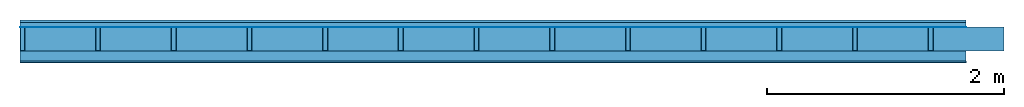
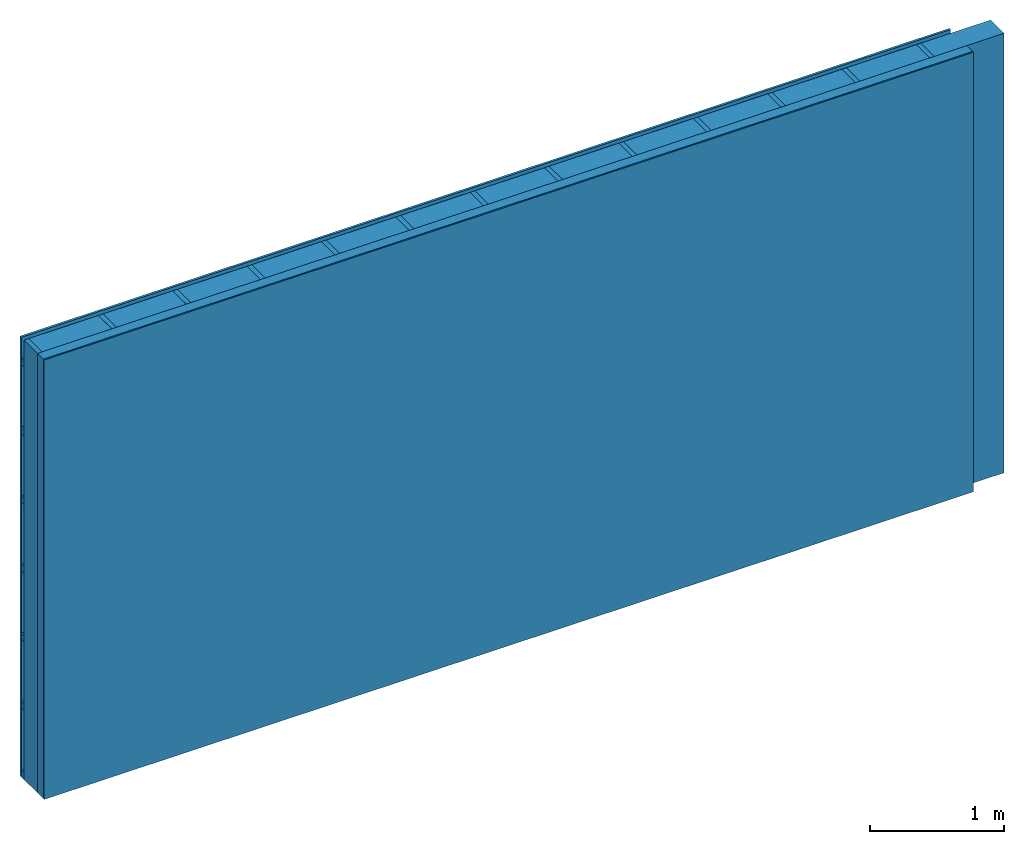
# One storey: 4 plates, 3 members, 1 element without a shape of its own.
"""IFC4 building model written with IfcOpenShell, lengths in metres."""

from ifc_helpers import new_model, si_unit, derived_unit, direction, frame, frame_2d, origin, origin_with_axes, place, context, project, spatial, rectangle, extrude, material, layer, layer_set, type_object, element, aggregate, save


model = new_model("IFC4")

# Units and contexts
plan_context = context("Plan", 3, precision=1e-05, world=origin(), true_north=direction((0.0, 1.0)))
model_context = context("Model", 3, precision=1e-05, world=origin(), true_north=direction((0.0, 1.0)))
ifc_project = project(units=[si_unit("LENGTHUNIT", "METRE"), derived_unit("SOUNDPRESSUREUNIT", [(si_unit("PRESSUREUNIT", "PASCAL", prefix="MICRO"), 0)]), si_unit("ENERGYUNIT", "JOULE", prefix="MEGA"), si_unit("MASSUNIT", "GRAM", prefix="KILO"), derived_unit("THERMALTRANSMITTANCEUNIT", [(si_unit("POWERUNIT", "WATT"), 1), (si_unit("AREAUNIT", "SQUARE_METRE"), -1), (si_unit("THERMODYNAMICTEMPERATUREUNIT", "KELVIN"), -1)]), derived_unit("AREADENSITYUNIT", [(si_unit("MASSUNIT", "GRAM", prefix="KILO"), 1), (si_unit("AREAUNIT", "SQUARE_METRE"), -1)]), derived_unit("USERDEFINED", [(si_unit("ENERGYUNIT", "JOULE", prefix="MEGA"), 1), (si_unit("AREAUNIT", "SQUARE_METRE"), -1)])], contexts=[plan_context, model_context])

# Site, building, storey
site = spatial("IfcSite", under=ifc_project)
building_placement = place(None, origin())
building = spatial("IfcBuilding", under=site, at=building_placement)
storey_placement = place(building_placement, origin())
storey = spatial("IfcBuildingStorey", under=building, at=storey_placement)

# Wall, members, plates
ifc_material_1 = material(Name="Wood cladding horizontal, closed")
ifc_layer_1 = layer(ifc_material_1, 0.02, Name="Cover 1st layer")
ifc_layer_2 = layer(None, 0.04, Name="Battens / profiles (ventilation)")
ifc_material_2 = material(Name="Vapor-permeable water barrier", Category="09.006")
ifc_layer_3 = layer(ifc_material_2, 0.0005, Name="outside 1st layer")
ifc_material_3 = material(Name="of the art")
ifc_layer_4 = layer(ifc_material_3, 0.0, Name="Bond")
ifc_layer_5 = layer(None, 0.2, Name="Support")
ifc_layer_6 = layer(ifc_material_3, 0.0, Name="Bond")
ifc_material_4 = material(Name="Solid timber panel")
ifc_layer_7 = layer(ifc_material_4, 0.087, Name="1st layer")
ifc_material_5 = material(Name="Plasterboard type A", Category="03.008")
ifc_layer_8 = layer(ifc_material_5, 0.0125, Name="Covering 1st layer")
ifc_material_6 = material(Name="joints", Category="04.017")
ifc_layer_9 = layer(ifc_material_6, 0.0, Name="Surface")
ifc_layer_set = layer_set([ifc_layer_1, ifc_layer_2, ifc_layer_3, ifc_layer_4, ifc_layer_5, ifc_layer_6, ifc_layer_7, ifc_layer_8, ifc_layer_9])
wall_type = type_object("IfcWallType", Name="D0985", PredefinedType="NOTDEFINED", material=ifc_layer_set)
wall_placement = place(None, frame((0.0, 0.0, 0.0), z_axis=(0.0, -1.0, 0.0), x_axis=(1.0, 0.0, 0.0)))
wall = element("IfcWall", 1, at=wall_placement, inside=storey, type_object=wall_type, material=ifc_layer_set, Name="Wall #1")
ifc_material_7 = material()
member_1_placement = place(wall_placement, origin())
member_1 = element("IfcMember", 2, at=member_1_placement, material=ifc_material_7, Name="Battens / profiles (ventilation)", context=plan_context, shape_type="SweptSolid", body=[
    extrude(rectangle(XDim=0.06, YDim=0.04, at=frame_2d((0.03, 0.02), x_axis=(1.0, 0.0))), frame((0.0, 0.0, 0.02), z_axis=(1.0, 0.0, 0.0), x_axis=(0.0, 1.0, 0.0)), (0.0, 0.0, 1.0), 8.0),
    extrude(rectangle(XDim=0.06, YDim=0.04, at=frame_2d((0.03, 0.02), x_axis=(1.0, 0.0))), frame((0.0, 0.625, 0.02), z_axis=(1.0, 0.0, 0.0), x_axis=(0.0, 1.0, 0.0)), (0.0, 0.0, 1.0), 8.0),
    extrude(rectangle(XDim=0.06, YDim=0.04, at=frame_2d((0.03, 0.02), x_axis=(1.0, 0.0))), frame((0.0, 1.25, 0.02), z_axis=(1.0, 0.0, 0.0), x_axis=(0.0, 1.0, 0.0)), (0.0, 0.0, 1.0), 8.0),
    extrude(rectangle(XDim=0.06, YDim=0.04, at=frame_2d((0.03, 0.02), x_axis=(1.0, 0.0))), frame((0.0, 1.875, 0.02), z_axis=(1.0, 0.0, 0.0), x_axis=(0.0, 1.0, 0.0)), (0.0, 0.0, 1.0), 8.0),
    extrude(rectangle(XDim=0.06, YDim=0.04, at=frame_2d((0.03, 0.02), x_axis=(1.0, 0.0))), frame((0.0, 2.5, 0.02), z_axis=(1.0, 0.0, 0.0), x_axis=(0.0, 1.0, 0.0)), (0.0, 0.0, 1.0), 8.0),
    extrude(rectangle(XDim=0.06, YDim=0.04, at=frame_2d((0.03, 0.02), x_axis=(1.0, 0.0))), frame((0.0, 3.125, 0.02), z_axis=(1.0, 0.0, 0.0), x_axis=(0.0, 1.0, 0.0)), (0.0, 0.0, 1.0), 8.0),
    extrude(rectangle(XDim=0.06, YDim=0.04, at=frame_2d((0.03, 0.02), x_axis=(1.0, 0.0))), frame((0.0, 3.75, 0.02), z_axis=(1.0, 0.0, 0.0), x_axis=(0.0, 1.0, 0.0)), (0.0, 0.0, 1.0), 8.0),
])
ifc_material_8 = material()
member_2_placement = place(wall_placement, origin())
member_2 = element("IfcMember", 3, at=member_2_placement, material=ifc_material_8, Name="Support", context=plan_context, shape_type="SweptSolid", body=[
    extrude(rectangle(XDim=0.04, YDim=0.2, at=frame_2d((0.02, 0.1), x_axis=(1.0, 0.0))), frame((0.0, 4.0, 0.0605), z_axis=(0.0, -1.0, 0.0), x_axis=(1.0, 0.0, 0.0)), (0.0, 0.0, 1.0), 4.0),
    extrude(rectangle(XDim=0.04, YDim=0.2, at=frame_2d((0.02, 0.1), x_axis=(1.0, 0.0))), frame((0.64, 4.0, 0.0605), z_axis=(0.0, -1.0, 0.0), x_axis=(1.0, 0.0, 0.0)), (0.0, 0.0, 1.0), 4.0),
    extrude(rectangle(XDim=0.04, YDim=0.2, at=frame_2d((0.02, 0.1), x_axis=(1.0, 0.0))), frame((1.28, 4.0, 0.0605), z_axis=(0.0, -1.0, 0.0), x_axis=(1.0, 0.0, 0.0)), (0.0, 0.0, 1.0), 4.0),
    extrude(rectangle(XDim=0.04, YDim=0.2, at=frame_2d((0.02, 0.1), x_axis=(1.0, 0.0))), frame((1.92, 4.0, 0.0605), z_axis=(0.0, -1.0, 0.0), x_axis=(1.0, 0.0, 0.0)), (0.0, 0.0, 1.0), 4.0),
    extrude(rectangle(XDim=0.04, YDim=0.2, at=frame_2d((0.02, 0.1), x_axis=(1.0, 0.0))), frame((2.56, 4.0, 0.0605), z_axis=(0.0, -1.0, 0.0), x_axis=(1.0, 0.0, 0.0)), (0.0, 0.0, 1.0), 4.0),
    extrude(rectangle(XDim=0.04, YDim=0.2, at=frame_2d((0.02, 0.1), x_axis=(1.0, 0.0))), frame((3.2, 4.0, 0.0605), z_axis=(0.0, -1.0, 0.0), x_axis=(1.0, 0.0, 0.0)), (0.0, 0.0, 1.0), 4.0),
    extrude(rectangle(XDim=0.04, YDim=0.2, at=frame_2d((0.02, 0.1), x_axis=(1.0, 0.0))), frame((3.84, 4.0, 0.0605), z_axis=(0.0, -1.0, 0.0), x_axis=(1.0, 0.0, 0.0)), (0.0, 0.0, 1.0), 4.0),
    extrude(rectangle(XDim=0.04, YDim=0.2, at=frame_2d((0.02, 0.1), x_axis=(1.0, 0.0))), frame((4.48, 4.0, 0.0605), z_axis=(0.0, -1.0, 0.0), x_axis=(1.0, 0.0, 0.0)), (0.0, 0.0, 1.0), 4.0),
    extrude(rectangle(XDim=0.04, YDim=0.2, at=frame_2d((0.02, 0.1), x_axis=(1.0, 0.0))), frame((5.12, 4.0, 0.0605), z_axis=(0.0, -1.0, 0.0), x_axis=(1.0, 0.0, 0.0)), (0.0, 0.0, 1.0), 4.0),
    extrude(rectangle(XDim=0.04, YDim=0.2, at=frame_2d((0.02, 0.1), x_axis=(1.0, 0.0))), frame((5.76, 4.0, 0.0605), z_axis=(0.0, -1.0, 0.0), x_axis=(1.0, 0.0, 0.0)), (0.0, 0.0, 1.0), 4.0),
    extrude(rectangle(XDim=0.04, YDim=0.2, at=frame_2d((0.02, 0.1), x_axis=(1.0, 0.0))), frame((6.4, 4.0, 0.0605), z_axis=(0.0, -1.0, 0.0), x_axis=(1.0, 0.0, 0.0)), (0.0, 0.0, 1.0), 4.0),
    extrude(rectangle(XDim=0.04, YDim=0.2, at=frame_2d((0.02, 0.1), x_axis=(1.0, 0.0))), frame((7.04, 4.0, 0.0605), z_axis=(0.0, -1.0, 0.0), x_axis=(1.0, 0.0, 0.0)), (0.0, 0.0, 1.0), 4.0),
    extrude(rectangle(XDim=0.04, YDim=0.2, at=frame_2d((0.02, 0.1), x_axis=(1.0, 0.0))), frame((7.68, 4.0, 0.0605), z_axis=(0.0, -1.0, 0.0), x_axis=(1.0, 0.0, 0.0)), (0.0, 0.0, 1.0), 4.0),
])
ifc_material_9 = material(Name="Mineral wool")
member_3_placement = place(wall_placement, origin())
member_3 = element("IfcMember", 4, at=member_3_placement, material=ifc_material_9, Name="Cavity", context=plan_context, shape_type="SweptSolid", body=[
    extrude(rectangle(XDim=0.6, YDim=0.2, at=frame_2d((0.3, 0.1), x_axis=(1.0, 0.0))), frame((0.04, 4.0, 0.0605), z_axis=(0.0, -1.0, 0.0), x_axis=(1.0, 0.0, 0.0)), (0.0, 0.0, 1.0), 4.0),
    extrude(rectangle(XDim=0.6, YDim=0.2, at=frame_2d((0.3, 0.1), x_axis=(1.0, 0.0))), frame((0.68, 4.0, 0.0605), z_axis=(0.0, -1.0, 0.0), x_axis=(1.0, 0.0, 0.0)), (0.0, 0.0, 1.0), 4.0),
    extrude(rectangle(XDim=0.6, YDim=0.2, at=frame_2d((0.3, 0.1), x_axis=(1.0, 0.0))), frame((1.32, 4.0, 0.0605), z_axis=(0.0, -1.0, 0.0), x_axis=(1.0, 0.0, 0.0)), (0.0, 0.0, 1.0), 4.0),
    extrude(rectangle(XDim=0.6, YDim=0.2, at=frame_2d((0.3, 0.1), x_axis=(1.0, 0.0))), frame((1.96, 4.0, 0.0605), z_axis=(0.0, -1.0, 0.0), x_axis=(1.0, 0.0, 0.0)), (0.0, 0.0, 1.0), 4.0),
    extrude(rectangle(XDim=0.6, YDim=0.2, at=frame_2d((0.3, 0.1), x_axis=(1.0, 0.0))), frame((2.6, 4.0, 0.0605), z_axis=(0.0, -1.0, 0.0), x_axis=(1.0, 0.0, 0.0)), (0.0, 0.0, 1.0), 4.0),
    extrude(rectangle(XDim=0.6, YDim=0.2, at=frame_2d((0.3, 0.1), x_axis=(1.0, 0.0))), frame((3.24, 4.0, 0.0605), z_axis=(0.0, -1.0, 0.0), x_axis=(1.0, 0.0, 0.0)), (0.0, 0.0, 1.0), 4.0),
    extrude(rectangle(XDim=0.6, YDim=0.2, at=frame_2d((0.3, 0.1), x_axis=(1.0, 0.0))), frame((3.88, 4.0, 0.0605), z_axis=(0.0, -1.0, 0.0), x_axis=(1.0, 0.0, 0.0)), (0.0, 0.0, 1.0), 4.0),
    extrude(rectangle(XDim=0.6, YDim=0.2, at=frame_2d((0.3, 0.1), x_axis=(1.0, 0.0))), frame((4.52, 4.0, 0.0605), z_axis=(0.0, -1.0, 0.0), x_axis=(1.0, 0.0, 0.0)), (0.0, 0.0, 1.0), 4.0),
    extrude(rectangle(XDim=0.6, YDim=0.2, at=frame_2d((0.3, 0.1), x_axis=(1.0, 0.0))), frame((5.16, 4.0, 0.0605), z_axis=(0.0, -1.0, 0.0), x_axis=(1.0, 0.0, 0.0)), (0.0, 0.0, 1.0), 4.0),
    extrude(rectangle(XDim=0.6, YDim=0.2, at=frame_2d((0.3, 0.1), x_axis=(1.0, 0.0))), frame((5.8, 4.0, 0.0605), z_axis=(0.0, -1.0, 0.0), x_axis=(1.0, 0.0, 0.0)), (0.0, 0.0, 1.0), 4.0),
    extrude(rectangle(XDim=0.6, YDim=0.2, at=frame_2d((0.3, 0.1), x_axis=(1.0, 0.0))), frame((6.44, 4.0, 0.0605), z_axis=(0.0, -1.0, 0.0), x_axis=(1.0, 0.0, 0.0)), (0.0, 0.0, 1.0), 4.0),
    extrude(rectangle(XDim=0.6, YDim=0.2, at=frame_2d((0.3, 0.1), x_axis=(1.0, 0.0))), frame((7.08, 4.0, 0.0605), z_axis=(0.0, -1.0, 0.0), x_axis=(1.0, 0.0, 0.0)), (0.0, 0.0, 1.0), 4.0),
    extrude(rectangle(XDim=0.6, YDim=0.2, at=frame_2d((0.3, 0.1), x_axis=(1.0, 0.0))), frame((7.72, 4.0, 0.0605), z_axis=(0.0, -1.0, 0.0), x_axis=(1.0, 0.0, 0.0)), (0.0, 0.0, 1.0), 4.0),
])
plate_1_placement = place(wall_placement, origin())
plate_1 = element("IfcPlate", 5, at=plate_1_placement, material=ifc_material_1, Name="Cover 1st layer", context=plan_context, shape_type="SweptSolid", body=[
    extrude(rectangle(XDim=8.0, YDim=4.0, at=frame_2d((4.0, 2.0), x_axis=(1.0, 0.0))), origin_with_axes(), (0.0, 0.0, 1.0), 0.02),
])
plate_2_placement = place(wall_placement, origin())
plate_2 = element("IfcPlate", 6, at=plate_2_placement, material=ifc_material_2, Name="outside 1st layer", context=plan_context, shape_type="SweptSolid", body=[
    extrude(rectangle(XDim=8.0, YDim=4.0, at=frame_2d((4.0, 2.0), x_axis=(1.0, 0.0))), frame((0.0, 0.0, 0.06), z_axis=(0.0, 0.0, 1.0), x_axis=(1.0, 0.0, 0.0)), (0.0, 0.0, 1.0), 0.0005),
])
plate_3_placement = place(wall_placement, origin())
plate_3 = element("IfcPlate", 7, at=plate_3_placement, material=ifc_material_4, Name="1st layer", context=plan_context, shape_type="SweptSolid", body=[
    extrude(rectangle(XDim=8.0, YDim=4.0, at=frame_2d((4.0, 2.0), x_axis=(1.0, 0.0))), frame((0.0, 0.0, 0.2605), z_axis=(0.0, 0.0, 1.0), x_axis=(1.0, 0.0, 0.0)), (0.0, 0.0, 1.0), 0.087),
])
plate_4_placement = place(wall_placement, origin())
plate_4 = element("IfcPlate", 8, at=plate_4_placement, material=ifc_material_5, Name="Covering 1st layer", context=plan_context, shape_type="SweptSolid", body=[
    extrude(rectangle(XDim=8.0, YDim=4.0, at=frame_2d((4.0, 2.0), x_axis=(1.0, 0.0))), frame((0.0, 0.0, 0.3475), z_axis=(0.0, 0.0, 1.0), x_axis=(1.0, 0.0, 0.0)), (0.0, 0.0, 1.0), 0.0125),
])
aggregate(wall, [plate_1, member_1, plate_2, member_2, member_3, plate_3, plate_4])

save(model, "model.ifc")
